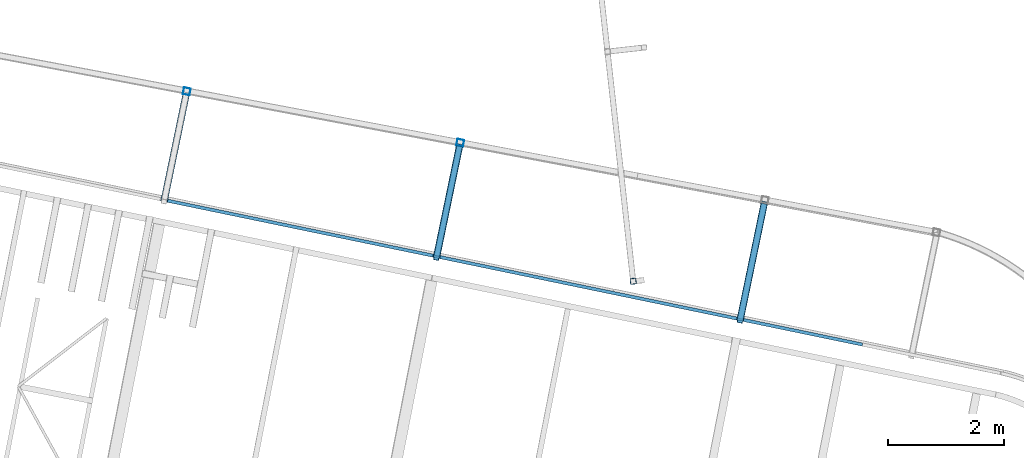
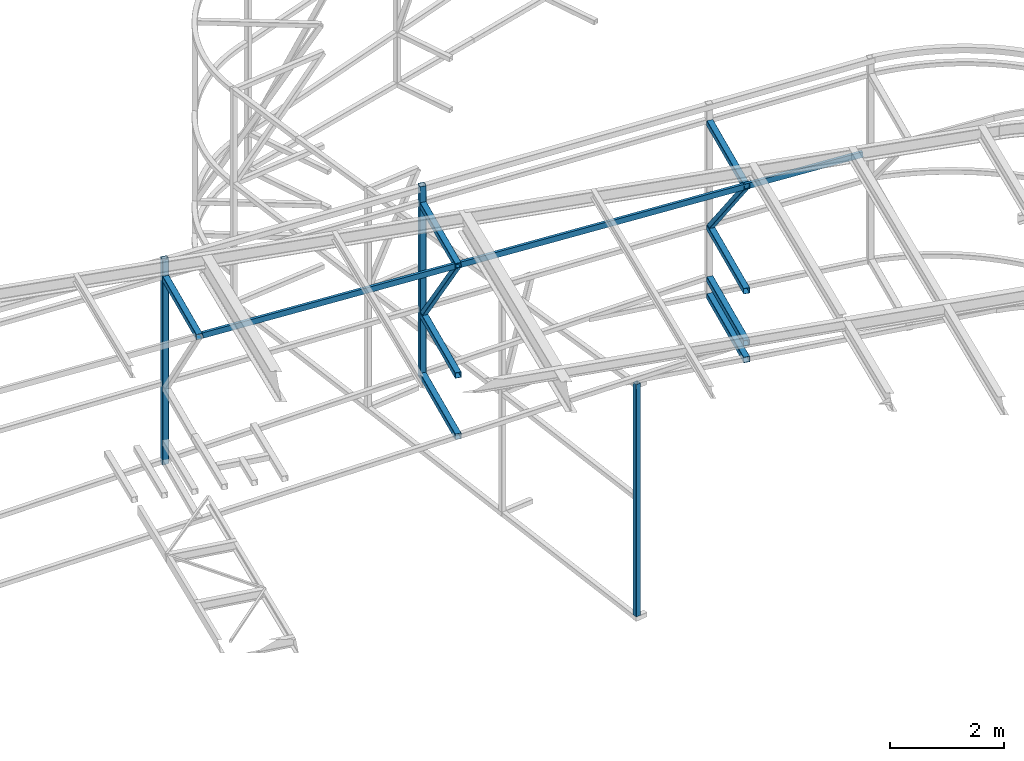
# One storey, part 100 of 215: 13 beams, 2 members, 15 elements without a shape of their own.
"""IFC2X3 building model written with IfcOpenShell, lengths in millimetres."""

from ifc_helpers import new_model, si_unit, frame, origin_with_axes, origin_2d_with_axis, place, context, subcontext, project, spatial, hollow_rectangle, u_section, extrude, clip, halfspace, material, type_object, element, aggregate, save


model = new_model("IFC2X3")

# Units and contexts
model_context = context("Model", 3, precision=1e-05, world=origin_with_axes())
body_context = subcontext(model_context, "Body", "Model", "MODEL_VIEW")
ifc_project = project(units=[si_unit("LENGTHUNIT", "METRE", prefix="MILLI"), si_unit("AREAUNIT", "SQUARE_METRE"), si_unit("VOLUMEUNIT", "CUBIC_METRE"), si_unit("MASSUNIT", "GRAM", prefix="KILO"), si_unit("TIMEUNIT", "SECOND"), si_unit("PLANEANGLEUNIT", "RADIAN"), si_unit("SOLIDANGLEUNIT", "STERADIAN"), si_unit("THERMODYNAMICTEMPERATUREUNIT", "DEGREE_CELSIUS"), si_unit("LUMINOUSINTENSITYUNIT", "LUMEN")], contexts=[model_context])

# Site, building, storey
site_placement = place(None, origin_with_axes())
site = spatial("IfcSite", under=ifc_project, at=site_placement, CompositionType="ELEMENT")
building_placement = place(site_placement, origin_with_axes())
building = spatial("IfcBuilding", under=site, at=building_placement, Name="Undefined", CompositionType="ELEMENT")
storey_placement = place(building_placement, origin_with_axes())
storey = spatial("IfcBuildingStorey", under=building, at=storey_placement, Name="Undefined", CompositionType="ELEMENT", Elevation=0.0)

# Assembly, beam
assembly_1_placement = place(storey_placement, origin_with_axes())
assembly_1 = element("IfcElementAssembly", 1, at=assembly_1_placement, inside=storey, Name="Steel Assembly", AssemblyPlace="NOTDEFINED", PredefinedType="RIGID_FRAME")
ifc_material = material(Name="STEEL/S275JR")
beam_type_1 = type_object("IfcBeamType", PredefinedType="NOTDEFINED")
beam_1_placement = place(assembly_1_placement, frame((92935.4152966707, 56696.064985034, 7637.8126742644), z_axis=(-0.111238280970791, 0.993793763739068, 0.0), x_axis=(0.0, 0.0, -1.0)))
beam_1 = element("IfcBeam", 2, at=beam_1_placement, type_object=beam_type_1, material=ifc_material, Name="LISSE", context=body_context, shape_type="SweptSolid", body=[
    extrude(hollow_rectangle(XDim=100.0, YDim=100.0, WallThickness=4.0, InnerFilletRadius=4.0, OuterFilletRadius=8.0, at=origin_2d_with_axis()), frame((4967.81146415482, 0.0, 0.0), z_axis=(-1.0, 0.0, 0.0), x_axis=(-6.93889390390723e-18, -1.0, -3.46944695195361e-18)), (0.0, 0.0, 1.0), 4967.8),
])
aggregate(assembly_1, [beam_1])

assembly_2_placement = place(storey_placement, origin_with_axes())
assembly_2 = element("IfcElementAssembly", 3, at=assembly_2_placement, inside=storey, Name="Steel Assembly", AssemblyPlace="NOTDEFINED", PredefinedType="RIGID_FRAME")
beam_type_2 = type_object("IfcBeamType", PredefinedType="NOTDEFINED")
beam_2_placement = place(assembly_2_placement, frame((85268.5620557058, 59958.5211429785, 11009.8724352533), z_axis=(-0.202341520089688, -0.979315020434076, -1.000000338979e-09), x_axis=(0.0, 0.0, -1.0)))
beam_2 = element("IfcBeam", 4, at=beam_2_placement, type_object=beam_type_2, material=ifc_material, Name="MONTANT", context=body_context, shape_type="Clipping", body=[
    clip(extrude(hollow_rectangle(XDim=120.0, YDim=120.0, WallThickness=5.0, InnerFilletRadius=5.0, OuterFilletRadius=10.0, at=origin_2d_with_axis()), frame((4389.7734490711, 0.0, 0.0), z_axis=(-1.0, 0.0, 0.0), x_axis=(-6.93889390390723e-18, -1.0, -3.46944695195361e-18)), (0.0, 0.0, 1.0), 4389.8), halfspace(frame((4364.11899500382, 103.701521924377, 39.2104171386163), z_axis=(0.988050902406614, 0.154123414224719, -0.00117789693607931), x_axis=(0.0, -0.007642341407296, -0.999970796882496)), False)),
])
aggregate(assembly_2, [beam_2])

assembly_3_placement = place(storey_placement, origin_with_axes())
assembly_3 = element("IfcElementAssembly", 5, at=assembly_3_placement, inside=storey, Name="Steel Assembly", AssemblyPlace="NOTDEFINED", PredefinedType="RIGID_FRAME")
beam_3_placement = place(assembly_3_placement, frame((89964.8656377599, 59074.1280075661, 11473.3855709206), z_axis=(-0.202742279955315, -0.979232131784145, -1.00000033831533e-09), x_axis=(0.0, 0.0, -1.0)))
beam_3 = element("IfcBeam", 6, at=beam_3_placement, type_object=beam_type_2, material=ifc_material, Name="MONTANT", context=body_context, shape_type="Clipping", body=[
    clip(extrude(hollow_rectangle(XDim=120.0, YDim=120.0, WallThickness=5.0, InnerFilletRadius=5.0, OuterFilletRadius=10.0, at=origin_2d_with_axis()), frame((4108.11691351023, -1.45519152285792e-11, -8.49538666239211e-22), z_axis=(-1.0, 0.0, 0.0), x_axis=(-6.93889390390723e-18, -1.0, -3.46944695195361e-18)), (0.0, 0.0, 1.0), 4108.1), halfspace(frame((4084.12038304563, 93.0735654514865, 39.2916580649326), z_axis=(0.988050902406614, 0.154123414224719, -0.00117789693607931), x_axis=(0.0, -0.007642341407296, -0.999970796882496)), False)),
])
aggregate(assembly_3, [beam_3])

assembly_4_placement = place(storey_placement, origin_with_axes())
assembly_4 = element("IfcElementAssembly", 7, at=assembly_4_placement, inside=storey, Name="Steel Assembly", AssemblyPlace="NOTDEFINED", PredefinedType="RIGID_FRAME")
beam_4_placement = place(assembly_4_placement, frame((95185.4590237245, 58029.9076270263, 7897.56238054807), z_axis=(0.979236903621654, -0.202719230921677, 0.0), x_axis=(-0.202719230921676, -0.979236903621654, 0.0)))
beam_4 = element("IfcBeam", 8, at=beam_4_placement, type_object=beam_type_2, material=ifc_material, context=body_context, shape_type="SweptSolid", body=[
    extrude(hollow_rectangle(XDim=120.0, YDim=120.0, WallThickness=5.0, InnerFilletRadius=5.0, OuterFilletRadius=10.0, at=origin_2d_with_axis()), frame((2055.82198168953, 0.0, 0.0), z_axis=(-1.0, 0.0, 0.0), x_axis=(-6.93889390390723e-18, -1.0, -3.46944695195361e-18)), (0.0, 0.0, 1.0), 2055.8),
])
aggregate(assembly_4, [beam_4])

assembly_5_placement = place(storey_placement, origin_with_axes())
assembly_5 = element("IfcElementAssembly", 9, at=assembly_5_placement, inside=storey, Name="Steel Assembly", AssemblyPlace="NOTDEFINED", PredefinedType="RIGID_FRAME")
beam_5_placement = place(assembly_5_placement, frame((95185.4453393099, 58029.9164743721, 9368.64139598709), z_axis=(-0.979232238823102, 0.202741762963372, 0.0), x_axis=(-0.202742279955315, -0.979232131784145, -1.00000033831533e-09)))
beam_5 = element("IfcBeam", 10, at=beam_5_placement, type_object=beam_type_2, material=ifc_material, context=body_context, shape_type="SweptSolid", body=[
    extrude(hollow_rectangle(XDim=120.0, YDim=120.0, WallThickness=5.0, InnerFilletRadius=5.0, OuterFilletRadius=10.0, at=origin_2d_with_axis()), frame((2055.40582506447, 0.0, -5.70489717983812e-14), z_axis=(-1.0, 0.0, 0.0), x_axis=(-6.93889390390723e-18, -1.0, -3.46944695195361e-18)), (0.0, 0.0, 1.0), 2055.4),
])
aggregate(assembly_5, [beam_5])

assembly_6_placement = place(storey_placement, origin_with_axes())
assembly_6 = element("IfcElementAssembly", 11, at=assembly_6_placement, inside=storey, Name="Steel Assembly", AssemblyPlace="NOTDEFINED", PredefinedType="RIGID_FRAME")
beam_6_placement = place(assembly_6_placement, frame((95185.4602172447, 58029.9133923896, 8256.36238050226), z_axis=(0.979236903621654, -0.202719230921677, 0.0), x_axis=(-0.202719230921676, -0.979236903621654, 0.0)))
beam_6 = element("IfcBeam", 12, at=beam_6_placement, type_object=beam_type_2, material=ifc_material, context=body_context, shape_type="SweptSolid", body=[
    extrude(hollow_rectangle(XDim=120.0, YDim=120.0, WallThickness=5.0, InnerFilletRadius=5.0, OuterFilletRadius=10.0, at=origin_2d_with_axis()), frame((2055.8218969094, -1.81898940354586e-12, -1.45519152283669e-11), z_axis=(-1.0, 0.0, 0.0), x_axis=(-6.93889390390723e-18, -1.0, -3.46944695195361e-18)), (0.0, 0.0, 1.0), 2055.8),
])
aggregate(assembly_6, [beam_6])

assembly_7_placement = place(storey_placement, origin_with_axes())
assembly_7 = element("IfcElementAssembly", 13, at=assembly_7_placement, inside=storey, Name="Steel Assembly", AssemblyPlace="NOTDEFINED", PredefinedType="RIGID_FRAME")
beam_7_placement = place(assembly_7_placement, frame((95185.4590730764, 58029.9078969252, 11596.8685294241), z_axis=(-0.979230850355674, 0.202748469073639, 0.0), x_axis=(-0.202748468021636, -0.979230846104497, 9.35540000100806e-05)))
beam_7 = element("IfcBeam", 14, at=beam_7_placement, type_object=beam_type_2, material=ifc_material, context=body_context, shape_type="SweptSolid", body=[
    extrude(hollow_rectangle(XDim=120.0, YDim=120.0, WallThickness=5.0, InnerFilletRadius=5.0, OuterFilletRadius=10.0, at=origin_2d_with_axis()), frame((2055.38939547013, -1.81901725926646e-12, 3.0264442920108e-15), z_axis=(-1.0, 0.0, 0.0), x_axis=(-6.93889390390723e-18, -1.0, -3.46944695195361e-18)), (0.0, 0.0, 1.0), 2055.4),
])
aggregate(assembly_7, [beam_7])

assembly_8_placement = place(storey_placement, origin_with_axes())
assembly_8 = element("IfcElementAssembly", 15, at=assembly_8_placement, inside=storey, Name="Steel Assembly", AssemblyPlace="NOTDEFINED", PredefinedType="RIGID_FRAME")
beam_8_placement = place(assembly_8_placement, frame((89952.9319800496, 59016.4892877942, 8735.98968610821), z_axis=(-0.979232238823102, 0.202741762963372, 0.0), x_axis=(-0.202742279955315, -0.979232131784145, -1.00000033831533e-09)))
beam_8 = element("IfcBeam", 16, at=beam_8_placement, type_object=beam_type_2, material=ifc_material, context=body_context, shape_type="SweptSolid", body=[
    extrude(hollow_rectangle(XDim=120.0, YDim=120.0, WallThickness=5.0, InnerFilletRadius=5.0, OuterFilletRadius=10.0, at=origin_2d_with_axis()), frame((1960.53180799316, 0.0, -5.44156888435998e-14), z_axis=(-1.0, 0.0, 0.0), x_axis=(-6.93889390390723e-18, -1.0, -3.46944695195361e-18)), (0.0, 0.0, 1.0), 1960.5),
])
aggregate(assembly_8, [beam_8])

assembly_9_placement = place(storey_placement, origin_with_axes())
assembly_9 = element("IfcElementAssembly", 17, at=assembly_9_placement, inside=storey, Name="Steel Assembly", AssemblyPlace="NOTDEFINED", PredefinedType="RIGID_FRAME")
beam_9_placement = place(assembly_9_placement, frame((89952.9319801223, 59016.4892879388, 7425.48636500297), z_axis=(0.979232107329781, -0.20274239806828, 0.0), x_axis=(-0.202742279955315, -0.979232131784145, -1.00000033831533e-09)))
beam_9 = element("IfcBeam", 18, at=beam_9_placement, type_object=beam_type_2, material=ifc_material, context=body_context, shape_type="SweptSolid", body=[
    extrude(hollow_rectangle(XDim=120.0, YDim=120.0, WallThickness=5.0, InnerFilletRadius=5.0, OuterFilletRadius=10.0, at=origin_2d_with_axis()), frame((1960.60696082523, 1.81898940354586e-12, 5.4417774753713e-14), z_axis=(-1.0, 0.0, 0.0), x_axis=(-6.93889390390723e-18, -1.0, -3.46944695195361e-18)), (0.0, 0.0, 1.0), 1960.6),
])
aggregate(assembly_9, [beam_9])

assembly_10_placement = place(storey_placement, origin_with_axes())
assembly_10 = element("IfcElementAssembly", 19, at=assembly_10_placement, inside=storey, Name="Steel Assembly", AssemblyPlace="NOTDEFINED", PredefinedType="RIGID_FRAME")
beam_10_placement = place(assembly_10_placement, frame((89952.9322328907, 59016.4905065203, 11075.2061030064), z_axis=(-0.979232238823102, 0.202741762963372, 0.0), x_axis=(-0.202742372100714, -0.979232112486443, -2.07440000099865e-05)))
beam_10 = element("IfcBeam", 20, at=beam_10_placement, type_object=beam_type_2, material=ifc_material, context=body_context, shape_type="SweptSolid", body=[
    extrude(hollow_rectangle(XDim=120.0, YDim=120.0, WallThickness=5.0, InnerFilletRadius=5.0, OuterFilletRadius=10.0, at=origin_2d_with_axis()), frame((1960.6142740269, -1.81898940354586e-12, 1.45517441789041e-11), z_axis=(-1.0, 0.0, 0.0), x_axis=(-6.93889390390723e-18, -1.0, -3.46944695195361e-18)), (0.0, 0.0, 1.0), 1960.6),
])
aggregate(assembly_10, [beam_10])

assembly_11_placement = place(storey_placement, origin_with_axes())
assembly_11 = element("IfcElementAssembly", 21, at=assembly_11_placement, inside=storey, Name="Steel Assembly", AssemblyPlace="NOTDEFINED", PredefinedType="RIGID_FRAME")
beam_11_placement = place(assembly_11_placement, frame((85256.4215641521, 59899.76224185, 10606.8513099681), z_axis=(0.979315017537065, -0.202341534110965, 0.0), x_axis=(-0.202341520089688, -0.979315020434076, -1.000000338979e-09)))
beam_11 = element("IfcBeam", 22, at=beam_11_placement, type_object=beam_type_2, material=ifc_material, context=body_context, shape_type="SweptSolid", body=[
    extrude(hollow_rectangle(XDim=120.0, YDim=120.0, WallThickness=5.0, InnerFilletRadius=5.0, OuterFilletRadius=10.0, at=origin_2d_with_axis()), frame((1873.33697915903, 0.0, -5.19955461786024e-14), z_axis=(-1.0, 0.0, 0.0), x_axis=(-6.93889390390723e-18, -1.0, -3.46944695195361e-18)), (0.0, 0.0, 1.0), 1873.3),
])
aggregate(assembly_11, [beam_11])

# Assembly, member
assembly_12_placement = place(storey_placement, origin_with_axes())
assembly_12 = element("IfcElementAssembly", 23, at=assembly_12_placement, inside=storey, Name="Steel Assembly", AssemblyPlace="NOTDEFINED", PredefinedType="RIGID_FRAME")
member_type = type_object("IfcMemberType", PredefinedType="NOTDEFINED")
member_1_placement = place(assembly_12_placement, frame((94768.7321618653, 56017.207862506, 11617.0608192608), z_axis=(-0.979270715440746, 0.202555754091165, -0.000179902000080825), x_axis=(0.13679742304399, 0.660701687212468, -0.738078414237351)))
member_1 = element("IfcMember", 24, at=member_1_placement, type_object=member_type, material=ifc_material, context=body_context, shape_type="SweptSolid", body=[
    extrude(hollow_rectangle(XDim=100.0, YDim=100.0, WallThickness=5.0, InnerFilletRadius=5.0, OuterFilletRadius=10.0, at=origin_2d_with_axis()), frame((3046.3151070541, -1.69104458605745e-13, -1.44525828730433e-11), z_axis=(-1.0, 0.0, 0.0), x_axis=(-6.93889390390723e-18, -1.0, -3.46944695195361e-18)), (0.0, 0.0, 1.0), 3046.3),
])
aggregate(assembly_12, [member_1])

assembly_13_placement = place(storey_placement, origin_with_axes())
assembly_13 = element("IfcElementAssembly", 25, at=assembly_13_placement, inside=storey, Name="Steel Assembly", AssemblyPlace="NOTDEFINED", PredefinedType="RIGID_FRAME")
member_2_placement = place(assembly_13_placement, frame((89555.4325584441, 57096.593639384, 11095.1654320209), z_axis=(-0.978901959273093, 0.204326079057002, 0.00134445100037592), x_axis=(0.129578756995445, 0.625857036977996, -0.769098377972961)))
member_2 = element("IfcMember", 26, at=member_2_placement, type_object=member_type, material=ifc_material, context=body_context, shape_type="SweptSolid", body=[
    extrude(hollow_rectangle(XDim=100.0, YDim=100.0, WallThickness=5.0, InnerFilletRadius=5.0, OuterFilletRadius=10.0, at=origin_2d_with_axis()), frame((3067.45640408552, -1.70278036342482e-13, -1.4486065519e-11), z_axis=(-1.0, 0.0, 0.0), x_axis=(-6.93889390390723e-18, -1.0, -3.46944695195361e-18)), (0.0, 0.0, 1.0), 3067.5),
])
aggregate(assembly_13, [member_2])

# Assembly, beam
assembly_14_placement = place(storey_placement, origin_with_axes())
assembly_14 = element("IfcElementAssembly", 27, at=assembly_14_placement, inside=storey, Name="Steel Assembly", AssemblyPlace="NOTDEFINED", PredefinedType="RIGID_FRAME")
beam_type_3 = type_object("IfcBeamType", Name="UPN120", PredefinedType="NOTDEFINED")
beam_12_placement = place(assembly_14_placement, frame((84944.7490297535, 58079.326012963, 10617.0652027582), z_axis=(0.095501801982912, -0.0197734269964623, -0.995232845821937), x_axis=(0.974562095802738, -0.201784882959157, 0.0975273419802593)))
beam_12 = element("IfcBeam", 28, at=beam_12_placement, type_object=beam_type_3, material=ifc_material, ObjectType="UPN120", context=body_context, shape_type="SweptSolid", body=[
    extrude(u_section(Depth=120.0, FlangeWidth=55.0, WebThickness=7.0, FlangeThickness=9.0, FilletRadius=9.0, EdgeRadius=4.5, FlangeSlope=0.0798299857122373, at=origin_2d_with_axis()), frame((4678.35747277133, 1.34716975713628e-13, -1.75406415124963e-12), z_axis=(-1.0, 0.0, 0.0), x_axis=(-6.93889390390723e-18, -1.0, -3.46944695195361e-18)), (0.0, 0.0, 1.0), 4678.4),
])
aggregate(assembly_14, [beam_12])

assembly_15_placement = place(storey_placement, origin_with_axes())
assembly_15 = element("IfcElementAssembly", 29, at=assembly_15_placement, inside=storey, Name="Steel Assembly", AssemblyPlace="NOTDEFINED", PredefinedType="RIGID_FRAME")
beam_13_placement = place(assembly_15_placement, frame((89615.3930209251, 57112.2181832505, 11084.4302148971), z_axis=(0.095501801982912, -0.0197734269964623, -0.995232845821937), x_axis=(0.974565189314063, -0.201769899065023, 0.097527430031429)))
beam_13 = element("IfcBeam", 30, at=beam_13_placement, type_object=beam_type_3, material=ifc_material, ObjectType="UPN120", context=body_context, shape_type="SweptSolid", body=[
    extrude(u_section(Depth=120.0, FlangeWidth=55.0, WebThickness=7.0, FlangeThickness=9.0, FilletRadius=9.0, EdgeRadius=4.5, FlangeSlope=0.0798299857122373, at=origin_2d_with_axis()), frame((7452.16316377089, -1.4416188326959e-11, 1.03419539096024e-13), z_axis=(-1.0, 0.0, 0.0), x_axis=(-6.93889390390723e-18, -1.0, -3.46944695195361e-18)), (0.0, 0.0, 1.0), 7452.2),
])
aggregate(assembly_15, [beam_13])

save(model, "model.ifc")
